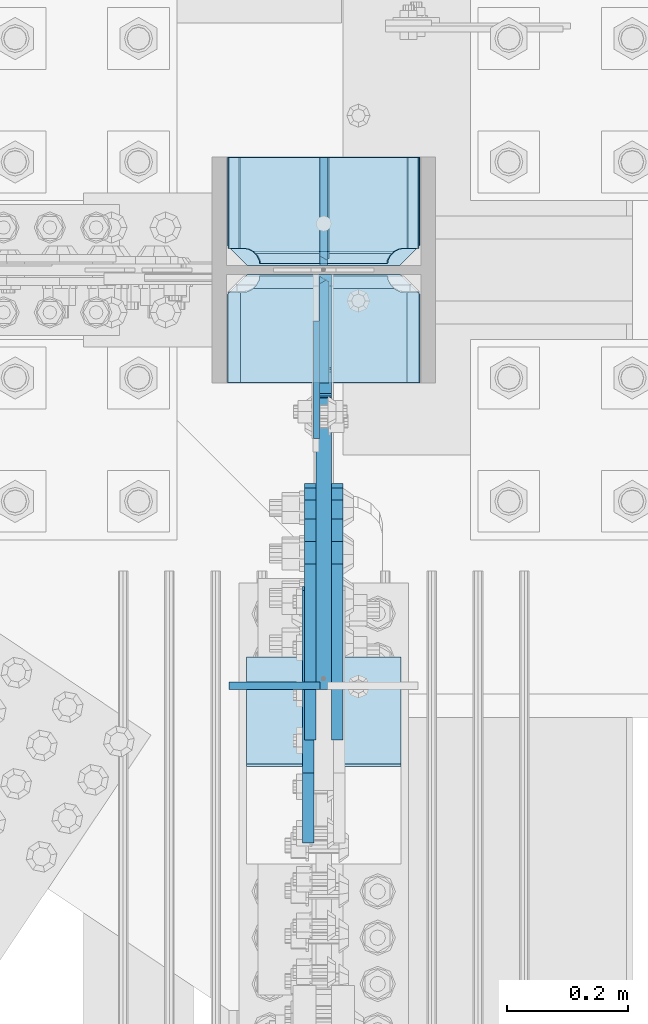
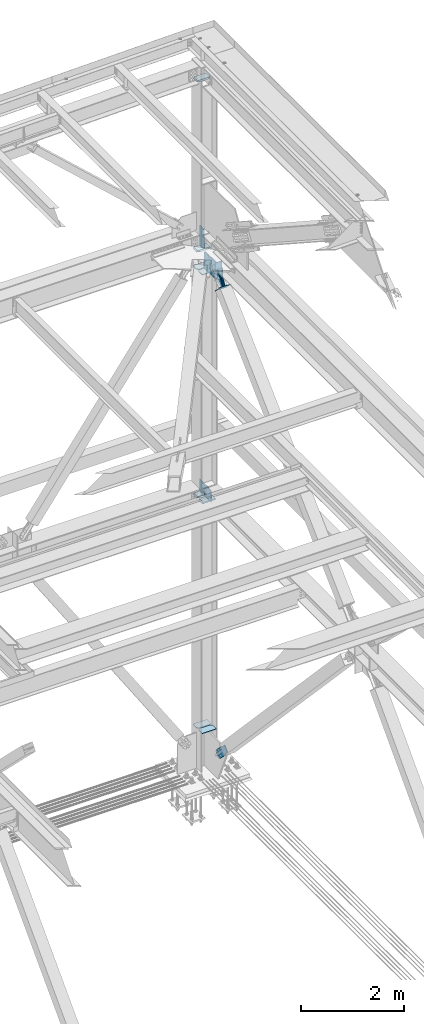
# One storey, part 3657 of 3843: 18 plates, 6 elements without a shape of their own.
"""IFC2X3 building model written with IfcOpenShell, lengths in millimetres."""

from ifc_helpers import new_model, si_unit, frame, origin_with_axes, place, context, subcontext, project, spatial, faceted_brep, material, type_object, element, aggregate, save


model = new_model("IFC2X3")

# Units and contexts
model_context = context("Model", 3, precision=1e-05, world=origin_with_axes())
body_context = subcontext(model_context, "Body", "Model", "MODEL_VIEW")
ifc_project = project(units=[si_unit("LENGTHUNIT", "METRE", prefix="MILLI"), si_unit("AREAUNIT", "SQUARE_METRE"), si_unit("VOLUMEUNIT", "CUBIC_METRE"), si_unit("MASSUNIT", "GRAM", prefix="KILO"), si_unit("TIMEUNIT", "SECOND"), si_unit("PLANEANGLEUNIT", "RADIAN"), si_unit("SOLIDANGLEUNIT", "STERADIAN"), si_unit("THERMODYNAMICTEMPERATUREUNIT", "DEGREE_CELSIUS"), si_unit("LUMINOUSINTENSITYUNIT", "LUMEN")], contexts=[model_context])

# Site, building, storey
site_placement = place(None, origin_with_axes())
site = spatial("IfcSite", under=ifc_project, at=site_placement, CompositionType="ELEMENT")
building_placement = place(site_placement, origin_with_axes())
building = spatial("IfcBuilding", under=site, at=building_placement, Name="Undefined", CompositionType="ELEMENT")
storey_placement = place(building_placement, origin_with_axes())
storey = spatial("IfcBuildingStorey", under=building, at=storey_placement, Name="Undefined", CompositionType="ELEMENT", Elevation=0.0)

# Assembly, plate
assembly_1_placement = place(storey_placement, origin_with_axes())
assembly_1 = element("IfcElementAssembly", 1, at=assembly_1_placement, inside=storey, Name="COLUMN", AssemblyPlace="NOTDEFINED", PredefinedType="RIGID_FRAME")
ifc_material_1 = material(Name="STEEL/A572-50")
plate_type_1 = type_object("IfcPlateType", PredefinedType="NOTDEFINED")
plate_1_placement = place(assembly_1_placement, frame((85648.7999999046, 104566.24374997, 41976.675), z_axis=(0.0, 0.707106781186548, 0.707106781186548), x_axis=(5.70000238222118e-08, 0.707106781186546, -0.707106781186546)))
plate_1 = element("IfcPlate", 2, at=plate_1_placement, type_object=plate_type_1, material=ifc_material_1, Name="PLATE", context=body_context, shape_type="Brep", body=[
    faceted_brep([(-192.380881421079, -6.35000000000582, 443.828052857963), (-197.56563466978, 6.35000000000582, 449.012806107159), (-312.063900183362, 6.35000000000582, 334.51454059362), (-312.063900184279, -6.35000000000582, 324.145034094792), (0.0, -6.3499999046162, 0.0), (-312.063900185356, -6.35000000000582, 312.063900214343), (-312.063900185356, 6.35000000000582, 312.063900214343), (7.27595761418343e-12, 6.3499999046162, 0.0), (22.4506403688138, 6.35000000000582, 1.01863406598568e-10), (12.0811338708518, -6.35000000000582, 7.27595761418343e-11), (136.94890588749, 6.34999990560755, 114.498265518749), (131.764152638782, -6.35000000000582, 119.68301876793)], [[[0, 1, 2, 3]], [[4, 5, 6, 7]], [[4, 7, 8, 9]], [[10, 11, 9, 8]], [[5, 4, 9, 11, 0, 3]], [[6, 5, 3, 2]], [[10, 8, 7, 6, 2, 1]], [[11, 10, 1, 0]]]),
])

assembly_2_placement = place(storey_placement, origin_with_axes())
assembly_2 = element("IfcElementAssembly", 3, at=assembly_2_placement, inside=storey, Name="BEAM", AssemblyPlace="NOTDEFINED", PredefinedType="RIGID_FRAME")
plate_type_2 = type_object("IfcPlateType", PredefinedType="NOTDEFINED")
plate_2_placement = place(assembly_2_placement, frame((85493.225, 103874.356415715, 42110.025), z_axis=(0.0, 0.0, -1.0), x_axis=(1.0, 0.0, 0.0)))
plate_2 = element("IfcPlate", 4, at=plate_2_placement, type_object=plate_type_2, material=ifc_material_1, Name="PLATE", context=body_context, shape_type="Brep", body=[
    faceted_brep([(0.0, -6.3499999046162, 0.0), (0.0, -6.34999999999854, 163.512499999997), (0.0, 6.34999999999854, 163.512499999997), (7.27595761418343e-12, 6.3499999046162, 0.0), (117.474999999991, -6.34999999999854, 163.512499999997), (117.474999999991, 6.34999999999854, 163.512499999997), (149.224999999991, -6.34999999999854, 131.762499999997), (149.224999999991, 6.34999999999854, 131.762499999997), (149.224999999991, -6.35000000000582, 0.0), (149.224999999991, 6.35000000000582, 0.0)], [[[0, 1, 2, 3]], [[1, 4, 5, 2]], [[4, 6, 7, 5]], [[6, 8, 9, 7]], [[8, 0, 3, 9]], [[5, 7, 9, 3, 2]], [[8, 6, 4, 1, 0]]]),
])
aggregate(assembly_2, [plate_2])

# Plate
plate_type_3 = type_object("IfcPlateType", PredefinedType="NOTDEFINED")
plate_3_placement = place(assembly_1_placement, frame((85807.55, 104566.24375, 41518.966879529), z_axis=(0.0, 1.0, 0.0), x_axis=(-1.0, 0.0, 0.0)))
plate_3 = element("IfcPlate", 5, at=plate_3_placement, type_object=plate_type_3, material=ifc_material_1, Name="CB_COL", context=body_context, shape_type="Brep", body=[
    faceted_brep([(0.0, -6.34999999999854, 33.3375015258789), (0.0, -6.34999999999854, 178.59375), (0.0, 6.34999999999854, 178.59375), (0.0, 6.34999999999854, 33.3375015258789), (317.499999999985, -6.34999999999854, 178.59375), (317.499999999985, 6.34999999999854, 178.59375), (317.499999999985, -6.34999999999854, 33.3375015258789), (317.499999999985, 6.34999999999854, 33.3375015258789), (284.162498474107, -6.34999999999854, 0.0), (284.162498474107, 6.34999999999854, 0.0), (33.3375015258789, -6.34999999999854, 0.0), (33.3375015258789, 6.34999999999854, 0.0)], [[[0, 1, 2, 3]], [[1, 4, 5, 2]], [[4, 6, 7, 5]], [[6, 8, 9, 7]], [[8, 10, 11, 9]], [[10, 0, 3, 11]], [[5, 7, 9, 11, 3, 2]], [[10, 8, 6, 4, 1, 0]]]),
])

plate_4_placement = place(assembly_1_placement, frame((85807.55, 104551.95625, 41518.966879529), z_axis=(0.0, -1.0, 0.0), x_axis=(-1.0, 0.0, 0.0)))
plate_4 = element("IfcPlate", 6, at=plate_4_placement, type_object=plate_type_3, material=ifc_material_1, Name="CB_COL", context=body_context, shape_type="Brep", body=[
    faceted_brep([(0.0, -6.34999999999854, 33.3375015258789), (0.0, -6.34999999999854, 178.59375), (0.0, 6.34999999999854, 178.59375), (0.0, 6.34999999999854, 33.3375015258789), (317.499999999985, -6.34999999999854, 178.59375), (317.499999999985, 6.34999999999854, 178.59375), (317.499999999985, -6.34999999999854, 33.3375015258789), (317.499999999985, 6.34999999999854, 33.3375015258789), (284.162498474107, -6.34999999999854, 0.0), (284.162498474107, 6.34999999999854, 0.0), (33.3375015258789, -6.34999999999854, 0.0), (33.3375015258789, 6.34999999999854, 0.0)], [[[0, 1, 2, 3]], [[1, 4, 5, 2]], [[4, 6, 7, 5]], [[6, 8, 9, 7]], [[8, 10, 11, 9]], [[10, 0, 3, 11]], [[5, 7, 9, 11, 3, 2]], [[10, 8, 6, 4, 1, 0]]]),
])

plate_5_placement = place(assembly_1_placement, frame((85807.55, 104566.24375, 30606.8951446559), z_axis=(0.0, 1.0, 0.0), x_axis=(-1.0, 0.0, 0.0)))
plate_5 = element("IfcPlate", 7, at=plate_5_placement, type_object=plate_type_3, material=ifc_material_1, Name="CB_COL", context=body_context, shape_type="Brep", body=[
    faceted_brep([(0.0, -6.34999999999854, 33.3375015258789), (0.0, -6.34999999999854, 178.59375), (0.0, 6.34999999999854, 178.59375), (0.0, 6.34999999999854, 33.3375015258789), (317.499999999985, -6.34999999999854, 178.59375), (317.499999999985, 6.34999999999854, 178.59375), (317.499999999985, -6.34999999999854, 33.3375015258789), (317.499999999985, 6.34999999999854, 33.3375015258789), (284.162498474107, -6.34999999999854, 0.0), (284.162498474107, 6.34999999999854, 0.0), (33.3375015258789, -6.34999999999854, 0.0), (33.3375015258789, 6.34999999999854, 0.0)], [[[0, 1, 2, 3]], [[1, 4, 5, 2]], [[4, 6, 7, 5]], [[6, 8, 9, 7]], [[8, 10, 11, 9]], [[10, 0, 3, 11]], [[5, 7, 9, 11, 3, 2]], [[10, 8, 6, 4, 1, 0]]]),
])

plate_6_placement = place(assembly_1_placement, frame((85807.55, 104551.95625, 30606.8951446559), z_axis=(0.0, -1.0, 0.0), x_axis=(-1.0, 0.0, 0.0)))
plate_6 = element("IfcPlate", 8, at=plate_6_placement, type_object=plate_type_3, material=ifc_material_1, Name="CB_COL", context=body_context, shape_type="Brep", body=[
    faceted_brep([(0.0, -6.34999999999854, 33.3375015258789), (0.0, -6.34999999999854, 178.59375), (0.0, 6.34999999999854, 178.59375), (0.0, 6.34999999999854, 33.3375015258789), (317.499999999985, -6.34999999999854, 178.59375), (317.499999999985, 6.34999999999854, 178.59375), (317.499999999985, -6.34999999999854, 33.3375015258789), (317.499999999985, 6.34999999999854, 33.3375015258789), (284.162498474107, -6.34999999999854, 0.0), (284.162498474107, 6.34999999999854, 0.0), (33.3375015258789, -6.34999999999854, 0.0), (33.3375015258789, 6.34999999999854, 0.0)], [[[0, 1, 2, 3]], [[1, 4, 5, 2]], [[4, 6, 7, 5]], [[6, 8, 9, 7]], [[8, 10, 11, 9]], [[10, 0, 3, 11]], [[5, 7, 9, 11, 3, 2]], [[10, 8, 6, 4, 1, 0]]]),
])

plate_type_4 = type_object("IfcPlateType", PredefinedType="NOTDEFINED")
plate_7_placement = place(assembly_1_placement, frame((85488.4625, 104566.24375, 41941.75), z_axis=(1.0, 0.0, 0.0), x_axis=(0.0, 1.0, 0.0)))
plate_7 = element("IfcPlate", 9, at=plate_7_placement, type_object=plate_type_4, material=ifc_material_1, Name="PLATE", context=body_context, shape_type="Brep", body=[
    faceted_brep([(16.7959640327026, 7.71646429280372, 270.56982732442), (21.5063709990791, 15.875, 275.280234290796), (21.5063709990791, 15.875, 45.3947535021725), (16.7959640327026, 7.71646429280372, 50.105160468549), (8.83016085001873, -6.0804942643299, 54.1639399157866), (3.17549995231093, -15.875, 55.0595502173092), (3.17549995231093, -15.875, 265.61543757566), (8.83016085001873, -6.0804942643299, 266.511047877182), (28.5750007629395, 15.875, 299.168629000924), (28.5750007629395, -15.875, 317.499500047692), (177.799999999999, -15.875, 317.499500047692), (177.799999999999, 15.875, 299.168629000924), (177.799999999999, 15.875, 21.5053709990898), (177.799999999999, -15.875, 3.17449995232164), (28.5750007629395, -15.875, 3.17449995232164), (28.5750007629395, 15.875, 21.5053709990898), (8.83016085001873, -15.875, 266.511047877182), (16.7959640327026, -15.875, 270.56982732442), (23.1176612314885, -15.875, 276.891524523206), (23.1176612314885, 15.875, 276.891524523206), (27.1764406787261, -15.875, 284.857327705889), (27.1764406787261, 15.875, 284.857327705889), (28.5750007629395, -15.875, 293.687488555908), (28.5750007629395, 15.875, 293.687488555908), (28.5750007629395, -15.875, 26.9874992370605), (28.5750007629395, 15.875, 26.9874992370605), (27.1764406787261, -15.875, 35.8176600870793), (27.1764406787261, 15.875, 35.8176600870793), (23.1176612314885, -15.875, 43.7834632697632), (23.1176612314885, 15.875, 43.7834632697632), (16.7959640327026, -15.875, 50.105160468549), (8.83016085001873, -15.875, 54.1639399157866)], [[[0, 1, 2, 3, 4, 5, 6, 7]], [[8, 9, 10, 11]], [[12, 13, 14, 15]], [[16, 7, 6]], [[16, 17, 0, 7]], [[17, 18, 19, 1, 0]], [[18, 20, 21, 19]], [[20, 22, 23, 21]], [[23, 22, 9, 8]], [[13, 12, 11, 10]], [[24, 25, 15, 14]], [[24, 26, 27, 25]], [[26, 28, 29, 27]], [[29, 28, 30, 3, 2]], [[30, 31, 4, 3]], [[31, 5, 4]], [[19, 21, 23, 8, 11, 12, 15, 25, 27, 29, 2, 1]], [[31, 30, 28, 26, 24, 14, 13, 10, 9, 22, 20, 18, 17, 16, 6, 5]]]),
])

plate_type_5 = type_object("IfcPlateType", PredefinedType="NOTDEFINED")
plate_8_placement = place(assembly_1_placement, frame((85636.89375, 104281.287501526, 36387.0875), z_axis=(0.0, 0.0, -1.0), x_axis=(0.0, 1.0, 0.0)))
plate_8 = element("IfcPlate", 10, at=plate_8_placement, type_object=plate_type_5, material=ifc_material_1, Name="PLATE", context=body_context, shape_type="Brep", body=[
    faceted_brep([(0.0, -4.76249999999709, 0.0), (1.45519152283669e-11, -4.76249999999709, 269.874990844721), (1.45519152283669e-11, 4.76249999999709, 269.874990844721), (0.0, 4.76249999999709, 0.0), (193.675000000003, -4.76249999999709, 269.874990844721), (193.675000000003, 4.76249999999709, 269.874990844721), (193.674999999996, -4.76249999999709, 0.0), (193.674999999996, 4.76249999999709, 0.0)], [[[0, 1, 2, 3]], [[1, 4, 5, 2]], [[4, 6, 7, 5]], [[6, 0, 3, 7]], [[5, 7, 3, 2]], [[6, 4, 1, 0]]]),
])

plate_type_6 = type_object("IfcPlateType", PredefinedType="NOTDEFINED")
plate_9_placement = place(assembly_1_placement, frame((85649.59375, 104551.955749998, 36121.975), z_axis=(0.0, -0.707106781186682, 0.707106781186413), x_axis=(0.0, -0.707106781186548, -0.707106781186548)))
plate_9 = element("IfcPlate", 11, at=plate_9_placement, type_object=plate_type_6, material=ifc_material_1, Name="PLATE", context=body_context, shape_type="Brep", body=[
    faceted_brep([(-180.113623446363, 7.9375, 197.565634661856), (13.470384184775, 7.9375, 3.98162703046546), (13.4703841731916, 3.06102272879798, -7.27595761418343e-12), (4.49012799309094, -7.9375, 7.27595761418343e-12), (-184.095250465922, -7.9375, 188.585378458934), (-184.095250465834, 3.06102272735734, 197.565634661623), (-184.095250465747, -7.9375, 206.545890861955), (-69.036072523144, -7.9375, 321.605068804558), (-62.5551309118164, 7.93749999991269, 315.124127196403), (22.4506403026729, -7.93750001103617, 0.0), (131.028876714015, 7.9375, 121.540119563797), (137.509818323713, -7.93750000094587, 115.059177954005), (128.529562034935, 7.9375, 124.039434242863), (128.529562034935, -7.9375, 124.039434242863), (-60.0558162178277, 7.9375, 312.624812503636), (-60.0558162178277, -7.9375, 312.624812503636)], [[[0, 1, 2, 3, 4, 5]], [[6, 7, 8, 0, 5]], [[9, 3, 2]], [[10, 11, 9, 2, 1]], [[12, 13, 11, 10]], [[14, 15, 13, 12]], [[15, 14, 8, 7]], [[4, 3, 9, 11, 13, 15, 7, 6]], [[6, 5, 4]], [[8, 14, 12, 10, 1, 0]]]),
])

plate_10_placement = place(assembly_1_placement, frame((85649.59375, 104566.24375, 36102.925), z_axis=(0.0, 0.0, 1.0), x_axis=(0.0, 1.0, 0.0)))
plate_10 = element("IfcPlate", 12, at=plate_10_placement, type_object=plate_type_6, material=ifc_material_1, Name="PLATE", context=body_context, shape_type="Brep", body=[
    faceted_brep([(3.17549995417357, 7.9375, 282.57550071711), (3.17549995417357, 7.9375, 15.874499282887), (9.52524962028838, -3.06058903608937, 9.52474961676489), (12.3409354775649, -7.9375, 12.3404354740123), (12.3409354775649, -7.9375, 286.109564523089), (9.52524961884774, -3.06058903358644, 288.925250381784), (177.800000000003, -7.9375, 286.109564523089), (177.800000000003, 7.93750000094587, 295.275000044581), (15.8749992816447, 7.9375, 295.275000044581), (15.8749992846424, 7.9375, 3.17499995241815), (177.800000000003, 7.9375, 3.17499995252001), (177.800000000003, -7.93749999991269, 12.3404354740123)], [[[0, 1, 2, 3, 4, 5]], [[6, 7, 8, 5, 4]], [[9, 2, 1]], [[9, 10, 11, 3, 2]], [[11, 10, 7, 6]], [[11, 6, 4, 3]], [[8, 0, 5]], [[10, 9, 1, 0, 8, 7]]]),
])

plate_type_7 = type_object("IfcPlateType", PredefinedType="NOTDEFINED")
plate_11_placement = place(assembly_1_placement, frame((85490.05, 104566.24375, 45988.2875), z_axis=(1.0, 0.0, 0.0), x_axis=(0.0, 1.0, 0.0)))
plate_11 = element("IfcPlate", 13, at=plate_11_placement, type_object=plate_type_7, material=ifc_material_1, Name="PLATE", context=body_context, shape_type="Brep", body=[
    faceted_brep([(16.7959640327026, 9.30383504699421, 267.394839531451), (19.6732843348727, 14.2874999999985, 270.272159833621), (19.6732843348727, 14.2874999999985, 47.2278401663789), (16.7959640327026, 9.30383504698693, 50.105160468549), (8.83016085001873, -4.4933407885037, 54.1639399157866), (3.17549995229638, -14.2874999999985, 55.0595502173092), (3.17549995229638, -14.2874999999985, 262.440449782691), (8.83016085003328, -4.49334078849643, 263.336060084213), (28.5750007629395, 14.2874999999985, 297.827215665093), (28.5750007629395, -14.2874999999985, 314.325000047669), (177.800003051758, -14.2874999999985, 314.325000047669), (177.800003051758, 14.2874999999985, 297.827215665093), (177.800003051758, 14.2874999999985, 19.6727843348781), (177.800003051758, -14.2874999999985, 3.17499995230173), (28.5750007629395, -14.2874999999985, 3.17499995230173), (28.5750007629395, 14.2874999999985, 19.6727843348781), (8.83016085003328, -14.2874999999985, 263.336060084213), (16.7959640327026, -14.2874999999985, 267.394839531451), (23.1176612314885, -14.2874999999985, 273.716536730237), (23.1176612314885, 14.2874999999985, 273.716536730237), (27.1764406787261, -14.2874999999985, 281.682339912921), (27.1764406787261, 14.2874999999985, 281.682339912921), (28.5750007629395, -14.2874999999985, 290.512500762939), (28.5750007629395, 14.2874999999985, 290.512500762939), (28.5750007629395, -14.2874999999985, 26.9874992370605), (28.5750007629395, 14.2874999999985, 26.9874992370605), (27.1764406787261, -14.2874999999985, 35.8176600870793), (27.1764406787261, 14.2874999999985, 35.8176600870793), (23.1176612314885, -14.2874999999985, 43.7834632697632), (23.1176612314885, 14.2874999999985, 43.7834632697632), (16.7959640327026, -14.2874999999985, 50.105160468549), (8.83016085001873, -14.2874999999985, 54.1639399157866)], [[[0, 1, 2, 3, 4, 5, 6, 7]], [[8, 9, 10, 11]], [[12, 13, 14, 15]], [[16, 7, 6]], [[16, 17, 0, 7]], [[17, 18, 19, 1, 0]], [[18, 20, 21, 19]], [[20, 22, 23, 21]], [[23, 22, 9, 8]], [[13, 12, 11, 10]], [[24, 25, 15, 14]], [[24, 26, 27, 25]], [[26, 28, 29, 27]], [[29, 28, 30, 3, 2]], [[30, 31, 4, 3]], [[31, 5, 4]], [[19, 21, 23, 8, 11, 12, 15, 25, 27, 29, 2, 1]], [[31, 30, 28, 26, 24, 14, 13, 10, 9, 22, 20, 18, 17, 16, 6, 5]]]),
])

plate_type_8 = type_object("IfcPlateType", PredefinedType="NOTDEFINED")
plate_12_placement = place(assembly_1_placement, frame((85488.4625, 104374.15625, 36085.4625), z_axis=(1.0, 0.0, 0.0), x_axis=(0.0, 1.0, 0.0)))
plate_12 = element("IfcPlate", 14, at=plate_12_placement, type_object=plate_type_8, material=ifc_material_1, Name="PLATE", context=body_context, shape_type="Brep", body=[
    faceted_brep([(160.070930155271, 7.74588927352306, 49.8019750199746), (154.461042336727, 17.4625000000015, 44.1920872014452), (154.461042336727, 17.4625000000015, 276.482900591524), (160.070930155271, 7.74588927352306, 270.873012772994), (168.479277841048, -6.81779612594983, 266.588745638888), (174.625000047687, -17.4625000000015, 265.615358866795), (174.625000047687, -17.4625000000015, 55.0596289261739), (168.479277841048, -6.81779612594983, 54.0862421540805), (147.637502670288, 17.4625000000015, 23.3384576632816), (147.637502670288, -17.4625000000015, 3.17449995232164), (0.0, -17.4625000000015, 3.17449995232164), (0.0, 17.4625000000015, 23.3384576632816), (0.0, 17.4625000000015, 297.335542336732), (0.0, -17.4625000000015, 317.499500047692), (147.637502670288, -17.4625000000015, 317.499500047692), (147.637502670288, 17.4625000000015, 297.335542336732), (147.637502670288, -17.4625000000015, 295.274988174438), (147.637502670288, 17.4625000000015, 295.274988174438), (149.113760516208, -17.4625000000015, 285.954262963729), (149.113760516208, 17.4625000000015, 285.954262963729), (153.398027650313, -17.4625000000015, 277.545915277951), (153.398027650313, 17.4625000000015, 277.545915277951), (160.070930155271, -17.4625000000015, 270.873012772994), (168.479277841048, -17.4625000000015, 266.588745638888), (168.479277841048, -17.4625000000015, 54.0862421540805), (160.070930155271, -17.4625000000015, 49.8019750199746), (153.398027650313, -17.4625000000015, 43.1290725150175), (153.398027650313, 17.4625000000015, 43.1290725150175), (149.113760516208, -17.4625000000015, 34.7207248292398), (149.113760516208, 17.4625000000015, 34.7207248292398), (147.637502670288, -17.4625000000015, 25.3999996185303), (147.637502670288, 17.4625000000015, 25.3999996185303)], [[[0, 1, 2, 3, 4, 5, 6, 7]], [[8, 9, 10, 11]], [[12, 13, 14, 15]], [[13, 12, 11, 10]], [[16, 17, 15, 14]], [[16, 18, 19, 17]], [[18, 20, 21, 19]], [[21, 20, 22, 3, 2]], [[22, 23, 4, 3]], [[23, 5, 4]], [[24, 7, 6]], [[24, 25, 0, 7]], [[25, 26, 27, 1, 0]], [[26, 28, 29, 27]], [[28, 30, 31, 29]], [[31, 30, 9, 8]], [[27, 29, 31, 8, 11, 12, 15, 17, 19, 21, 2, 1]], [[9, 30, 28, 26, 25, 24, 6, 5, 23, 22, 20, 18, 16, 14, 13, 10]]]),
])

plate_13_placement = place(assembly_1_placement, frame((85809.1375, 104744.04375, 36085.4625), z_axis=(-1.0, 0.0, 0.0), x_axis=(0.0, -1.0, 0.0)))
plate_13 = element("IfcPlate", 15, at=plate_13_placement, type_object=plate_type_8, material=ifc_material_1, Name="PLATE", context=body_context, shape_type="Brep", body=[
    faceted_brep([(161.004039019055, 6.12926429974323, 50.105160468549), (154.682341820269, 17.0787650381244, 43.7834632697632), (154.460792336729, 17.4625000000015, 43.3486479258863), (154.460792336729, 17.4625000000015, 277.326339867082), (154.682341820269, 17.0787650381244, 276.891524523206), (161.004039019055, 6.1292642997505, 270.56982732442), (168.969842201739, -7.66791153574013, 266.511047877182), (174.624750047686, -17.4625000000015, 265.615410186598), (174.624750047686, -17.4625000000015, 55.0595898134052), (168.969842201739, -7.66791153574013, 54.1639399157866), (0.0, 17.4625000000015, 297.335542336732), (0.0, -17.4625000000015, 317.499500047692), (149.225002288818, -17.4625000000015, 317.499500047663), (149.225002288818, 17.4625000000015, 297.335542336703), (149.225002288818, 17.4625000000015, 23.3394576632563), (149.225002288818, -17.4625000000015, 3.17549995229638), (0.0, -17.4625000000015, 3.17549995229638), (0.0, 17.4625000000015, 23.3394576632563), (149.225002288818, -17.4625000000015, 293.687488555908), (149.225002288818, 17.4625000000015, 293.687488555908), (150.623562373032, -17.4625000000015, 284.857327705889), (150.623562373032, 17.4625000000015, 284.857327705889), (154.682341820269, -17.4625000000015, 276.891524523206), (161.004039019055, -17.4625000000015, 270.56982732442), (168.969842201739, -17.4625000000015, 266.511047877182), (168.969842201739, -17.4625000000015, 54.1639399157866), (161.004039019055, -17.4625000000015, 50.105160468549), (154.682341820269, -17.4625000000015, 43.7834632697632), (150.623562373032, -17.4625000000015, 35.8176600870793), (150.623562373032, 17.4625000000015, 35.8176600870793), (149.225002288818, -17.4625000000015, 26.9874992370605), (149.225002288818, 17.4625000000015, 26.9874992370605)], [[[0, 1, 2, 3, 4, 5, 6, 7, 8, 9]], [[10, 11, 12, 13]], [[14, 15, 16, 17]], [[17, 16, 11, 10]], [[18, 19, 13, 12]], [[18, 20, 21, 19]], [[21, 20, 22, 4, 3]], [[22, 23, 5, 4]], [[23, 24, 6, 5]], [[24, 7, 6]], [[25, 9, 8]], [[25, 26, 0, 9]], [[26, 27, 1, 0]], [[27, 28, 29, 2, 1]], [[28, 30, 31, 29]], [[31, 30, 15, 14]], [[29, 31, 14, 17, 10, 13, 19, 21, 3, 2]], [[15, 30, 28, 27, 26, 25, 8, 7, 24, 23, 22, 20, 18, 12, 11, 16]]]),
])

# Assembly, plate
assembly_3_placement = place(storey_placement, origin_with_axes())
assembly_3 = element("IfcElementAssembly", 16, at=assembly_3_placement, inside=storey, AssemblyPlace="NOTDEFINED", PredefinedType="RIGID_FRAME")
ifc_material_2 = material(Name="STEEL/A36")
plate_type_9 = type_object("IfcPlateType", PredefinedType="NOTDEFINED")
plate_14_placement = place(assembly_3_placement, frame((85626.575, 103873.386644259, 41448.6697557771), z_axis=(0.0, -0.693740529148912, 0.720225019154561), x_axis=(0.0, 0.720225019154586, 0.693740529148886)))
plate_14 = element("IfcPlate", 17, at=plate_14_placement, type_object=plate_type_9, material=ifc_material_2, context=body_context, shape_type="Brep", body=[
    faceted_brep([(0.0, -9.52500000000146, 0.0), (-1.04046193882823e-09, -9.52499999999418, 127.02645557576), (-1.04046193882823e-09, 9.52499999999418, 127.02645557576), (0.0, 9.52500000000146, 0.0), (69.8499999968899, -9.52499999999418, 127.026455575353), (69.8499999968899, 9.52499999999418, 127.026455575353), (171.449999994144, -9.52499999999418, 160.350727789177), (171.449999994144, 9.52499999999418, 160.350727789177), (390.129297651329, -9.52499999999418, 160.350727787925), (390.129297651329, 9.52499999999418, 160.350727787925), (427.187405116643, -9.52499999999418, 152.979411901222), (427.187405116643, 9.52499999999418, 152.979411901222), (458.603751652932, -9.52499999999418, 131.987680264123), (458.603751652932, 9.52499999999418, 131.987680264123), (479.595483290015, -9.52499999999418, 100.571333727821), (479.595483290015, 9.52499999999418, 100.571333727821), (486.966799176706, -9.52499999999418, 63.5132293100978), (486.966799176706, 9.52499999999418, 63.5132293100978), (479.595483290208, -9.52499999999418, 26.4551218441993), (479.595483290208, 9.52499999999418, 26.4551218441993), (458.603751652907, -9.52499999999418, -4.96122469259717), (458.603751652907, 9.52499999999418, -4.96122469259717), (427.187405116098, -9.52499999999418, -25.9529563298856), (427.187405116098, 9.52499999999418, -25.9529563298856), (390.129299180044, -9.52499999999418, -33.3242722163704), (390.129299180044, 9.52499999999418, -33.3242722163704), (171.449999995208, -9.52499999999418, -33.3242722151044), (171.449999995208, 9.52499999999418, -33.3242722151044), (69.8499999979995, -9.52499999999418, -4.00177668780088e-10), (69.8499999979995, 9.52499999999418, -4.00177668780088e-10)], [[[0, 1, 2, 3]], [[1, 4, 5, 2]], [[4, 6, 7, 5]], [[6, 8, 9, 7]], [[8, 10, 11, 9]], [[10, 12, 13, 11]], [[12, 14, 15, 13]], [[14, 16, 17, 15]], [[16, 18, 19, 17]], [[18, 20, 21, 19]], [[20, 22, 23, 21]], [[22, 24, 25, 23]], [[24, 26, 27, 25]], [[26, 28, 29, 27]], [[28, 0, 3, 29]], [[5, 7, 9, 11, 13, 15, 17, 19, 21, 23, 25, 27, 29, 3, 2]], [[28, 26, 24, 22, 20, 18, 16, 14, 12, 10, 8, 6, 4, 1, 0]]]),
])
aggregate(assembly_3, [plate_14])

assembly_4_placement = place(storey_placement, origin_with_axes())
assembly_4 = element("IfcElementAssembly", 18, at=assembly_4_placement, inside=storey, AssemblyPlace="NOTDEFINED", PredefinedType="RIGID_FRAME")
plate_15_placement = place(assembly_4_placement, frame((85671.025, 103873.386644259, 41448.6697557771), z_axis=(0.0, -0.693740529148912, 0.720225019154561), x_axis=(0.0, 0.720225019154586, 0.693740529148886)))
plate_15 = element("IfcPlate", 19, at=plate_15_placement, type_object=plate_type_9, material=ifc_material_2, context=body_context, shape_type="Brep", body=[
    faceted_brep([(0.0, -9.52500000000146, 0.0), (-1.04046193882823e-09, -9.52499999999418, 127.02645557576), (-1.04046193882823e-09, 9.52499999999418, 127.02645557576), (0.0, 9.52500000000146, 0.0), (69.8499999968899, -9.52499999999418, 127.026455575353), (69.8499999968899, 9.52499999999418, 127.026455575353), (171.449999994144, -9.52499999999418, 160.350727789177), (171.449999994144, 9.52499999999418, 160.350727789177), (390.129297651329, -9.52499999999418, 160.350727787925), (390.129297651329, 9.52499999999418, 160.350727787925), (427.187405116643, -9.52499999999418, 152.979411901222), (427.187405116643, 9.52499999999418, 152.979411901222), (458.603751652932, -9.52499999999418, 131.987680264123), (458.603751652932, 9.52499999999418, 131.987680264123), (479.595483290015, -9.52499999999418, 100.571333727821), (479.595483290015, 9.52499999999418, 100.571333727821), (486.966799176706, -9.52499999999418, 63.5132293100978), (486.966799176706, 9.52499999999418, 63.5132293100978), (479.595483290208, -9.52499999999418, 26.4551218441993), (479.595483290208, 9.52499999999418, 26.4551218441993), (458.603751652907, -9.52499999999418, -4.96122469259717), (458.603751652907, 9.52499999999418, -4.96122469259717), (427.187405116098, -9.52499999999418, -25.9529563298856), (427.187405116098, 9.52499999999418, -25.9529563298856), (390.129299180044, -9.52499999999418, -33.3242722163704), (390.129299180044, 9.52499999999418, -33.3242722163704), (171.449999995208, -9.52499999999418, -33.3242722151044), (171.449999995208, 9.52499999999418, -33.3242722151044), (69.8499999979995, -9.52499999999418, -4.00177668780088e-10), (69.8499999979995, 9.52499999999418, -4.00177668780088e-10)], [[[0, 1, 2, 3]], [[1, 4, 5, 2]], [[4, 6, 7, 5]], [[6, 8, 9, 7]], [[8, 10, 11, 9]], [[10, 12, 13, 11]], [[12, 14, 15, 13]], [[14, 16, 17, 15]], [[16, 18, 19, 17]], [[18, 20, 21, 19]], [[20, 22, 23, 21]], [[22, 24, 25, 23]], [[24, 26, 27, 25]], [[26, 28, 29, 27]], [[28, 0, 3, 29]], [[5, 7, 9, 11, 13, 15, 17, 19, 21, 23, 25, 27, 29, 3, 2]], [[28, 26, 24, 22, 20, 18, 16, 14, 12, 10, 8, 6, 4, 1, 0]]]),
])
aggregate(assembly_4, [plate_15])

assembly_5_placement = place(storey_placement, origin_with_axes())
assembly_5 = element("IfcElementAssembly", 20, at=assembly_5_placement, inside=storey, AssemblyPlace="NOTDEFINED", PredefinedType="RIGID_FRAME")
plate_16_placement = place(assembly_5_placement, frame((85623.4, 103731.246167624, 30687.9771468618), z_axis=(0.0, -0.72828277798531, -0.68527672898618), x_axis=(0.0, 0.685276728986183, -0.728282777985308)))
plate_16 = element("IfcPlate", 21, at=plate_16_placement, type_object=plate_type_9, material=ifc_material_2, context=body_context, shape_type="Brep", body=[
    faceted_brep([(0.0, -9.52500000000146, 0.0), (1.71894498635083e-09, -9.52499999999418, 158.39421297863), (1.71894498635083e-09, 9.52499999999418, 158.39421297863), (0.0, 9.52500000000146, 0.0), (69.8500000010408, -9.52499999999418, 158.394212979103), (69.8500000010408, 9.52499999999418, 158.394212979103), (171.450000002631, -9.52499999999418, 176.034606488582), (171.450000002631, 9.52499999999418, 176.034606488582), (390.129297671807, -9.52499999999418, 176.034606487716), (390.129297671807, 9.52499999999418, 176.034606487716), (427.187405137312, -9.52499999999418, 168.663290600991), (427.187405137312, 9.52499999999418, 168.663290600991), (458.60375167372, -9.52499999999418, 147.671558963724), (458.60375167372, 9.52499999999418, 147.671558963724), (479.59548331075, -9.52499999999418, 116.255212427161), (479.59548331075, 9.52499999999418, 116.255212427161), (486.966799197198, -9.52499999999418, 79.1971080138683), (486.966799197198, 9.52499999999418, 79.1971080138683), (479.595483310488, -9.52499999999418, 42.1390005483336), (479.595483310488, 9.52499999999418, 42.1390005483336), (458.603751673207, -9.52499999999418, 10.7226540119082), (458.603751673207, 9.52499999999418, 10.7226540119082), (427.18740513661, -9.52499999999418, -10.2690776251402), (427.18740513661, 9.52499999999418, -10.2690776251402), (390.129299195723, -9.52499999999418, -17.6403935115741), (390.129299195723, 9.52499999999418, -17.6403935115741), (171.450000001962, -9.52499999999418, -17.6403935107155), (171.450000001962, 9.52499999999418, -17.6403935107155), (69.8499999979995, -9.52499999999418, -4.00177668780088e-10), (69.8499999979995, 9.52499999999418, -4.00177668780088e-10)], [[[0, 1, 2, 3]], [[1, 4, 5, 2]], [[4, 6, 7, 5]], [[6, 8, 9, 7]], [[8, 10, 11, 9]], [[10, 12, 13, 11]], [[12, 14, 15, 13]], [[14, 16, 17, 15]], [[16, 18, 19, 17]], [[18, 20, 21, 19]], [[20, 22, 23, 21]], [[22, 24, 25, 23]], [[24, 26, 27, 25]], [[26, 28, 29, 27]], [[28, 0, 3, 29]], [[5, 7, 9, 11, 13, 15, 17, 19, 21, 23, 25, 27, 29, 3, 2]], [[28, 26, 24, 22, 20, 18, 16, 14, 12, 10, 8, 6, 4, 1, 0]]]),
])
aggregate(assembly_5, [plate_16])

assembly_6_placement = place(storey_placement, origin_with_axes())
assembly_6 = element("IfcElementAssembly", 22, at=assembly_6_placement, inside=storey, Name="Plate", AssemblyPlace="NOTDEFINED", PredefinedType="RIGID_FRAME")
plate_type_10 = type_object("IfcPlateType", PredefinedType="NOTDEFINED")
plate_17_placement = place(assembly_6_placement, frame((85775.8, 103919.716705653, 41405.1476203272), z_axis=(0.0, -0.693740529148912, 0.720225019154561), x_axis=(-1.0, 0.0, 0.0)))
plate_17 = element("IfcPlate", 23, at=plate_17_placement, type_object=plate_type_10, material=ifc_material_2, Name="Plate", context=body_context, shape_type="Brep", body=[
    faceted_brep([(0.0, -3.17499999999927, 0.0), (0.0, -3.17499999965185, 254.000000005151), (0.0, 3.17500000035216, 254.000000005166), (0.0, 3.17499999999927, 0.0), (254.0, -3.17499999965185, 254.000000005151), (254.0, 3.17500000035216, 254.000000005166), (254.0, -3.17500000000291, 0.0), (254.0, 3.17499999999927, 1.45519152283669e-11)], [[[0, 1, 2, 3]], [[1, 4, 5, 2]], [[4, 6, 7, 5]], [[6, 0, 3, 7]], [[5, 7, 3, 2]], [[6, 4, 1, 0]]]),
])
aggregate(assembly_6, [plate_17])

# Plate
plate_type_11 = type_object("IfcPlateType", PredefinedType="NOTDEFINED")
plate_18_placement = place(assembly_1_placement, frame((85648.8, 103868.006415715, 42468.8), z_axis=(0.0, 0.0, -1.0), x_axis=(0.0, 1.0, 0.0)))
plate_18 = element("IfcPlate", 24, at=plate_18_placement, type_object=plate_type_11, material=ifc_material_1, Name="CB", context=body_context, shape_type="Brep", body=[
    faceted_brep([(530.756084285444, -12.6999999999971, 555.625000190717), (530.756084285444, 12.6999999999971, 555.625000190717), (530.756084285444, 12.6999999999971, 542.925000000003), (530.756084285444, -12.6999999999971, 542.925000000003), (529.78935436286, -12.6999999999971, 560.485079708764), (529.78935436286, 12.6999999999971, 560.485079708764), (527.036340462379, -12.6999999999971, 564.605256176917), (527.036340462379, 12.6999999999971, 564.605256176917), (522.916163994218, -12.6999999999971, 567.358270077391), (522.916163994218, 12.6999999999971, 567.358270077391), (518.056084476179, -12.6999999999971, 568.324999999983), (518.056084476179, 12.6999999999971, 568.324999999983), (492.656084094706, -12.6999999999971, 568.324999999983), (492.656084094706, 12.6999999999971, 568.324999999983), (487.796004576667, -12.6999999999971, 567.358270077391), (487.796004576667, 12.6999999999971, 567.358270077391), (483.675828108506, -12.6999999999971, 564.605256176917), (483.675828108506, 12.6999999999971, 564.605256176917), (480.922814208025, -12.6999999999971, 560.485079708764), (480.922814208025, 12.6999999999971, 560.485079708764), (479.956084285441, -12.6999999999971, 555.625000190717), (479.956084285441, 12.6999999999971, 555.625000190717), (479.956084285441, -12.6999999999971, 542.925000000003), (479.956084285441, 12.6999999999971, 542.925000000003), (0.0, -12.7000000000007, 542.925000000003), (0.0, 12.7000000000007, 542.925000000003), (0.0, -12.6999999999971, 767.406108913128), (0.0, 12.6999999999971, 767.406108913128), (169.602215863677, -12.6999999999971, 943.483120470948), (169.602215863677, 12.6999999999971, 943.483120470948), (664.899835048389, -12.6999999999971, 943.483120470948), (664.899835048389, 12.6999999999971, 943.483120470948), (683.949834285449, -12.6999999999971, 924.433121233888), (683.949834285449, 12.6999999999971, 924.433121233888), (683.949834285449, -12.6999999999971, 561.974999999991), (683.949834285449, 12.6999999999971, 561.974999999991), (664.899834285461, 12.6999999999971, 542.925000000003), (664.899834285461, -12.6999999999971, 542.925000000003)], [[[0, 1, 2, 3]], [[4, 5, 1, 0]], [[6, 7, 5, 4]], [[8, 9, 7, 6]], [[10, 11, 9, 8]], [[12, 13, 11, 10]], [[14, 15, 13, 12]], [[16, 17, 15, 14]], [[18, 19, 17, 16]], [[20, 21, 19, 18]], [[22, 23, 21, 20]], [[24, 25, 23, 22]], [[26, 27, 25, 24]], [[26, 28, 29, 27]], [[28, 30, 31, 29]], [[30, 32, 33, 31]], [[33, 32, 34, 35]], [[2, 1, 5, 7, 9, 11, 13, 15, 17, 19, 21, 23, 25, 27, 29, 31, 33, 35, 36]], [[3, 2, 36, 37]], [[32, 30, 28, 26, 24, 22, 20, 18, 16, 14, 12, 10, 8, 6, 4, 0, 3, 37, 34]], [[36, 35, 34, 37]]]),
])

aggregate(assembly_1, [plate_9, plate_8, plate_10, plate_7, plate_1, plate_12, plate_11, plate_13, plate_3, plate_4, plate_18, plate_5, plate_6])

save(model, "model.ifc")
